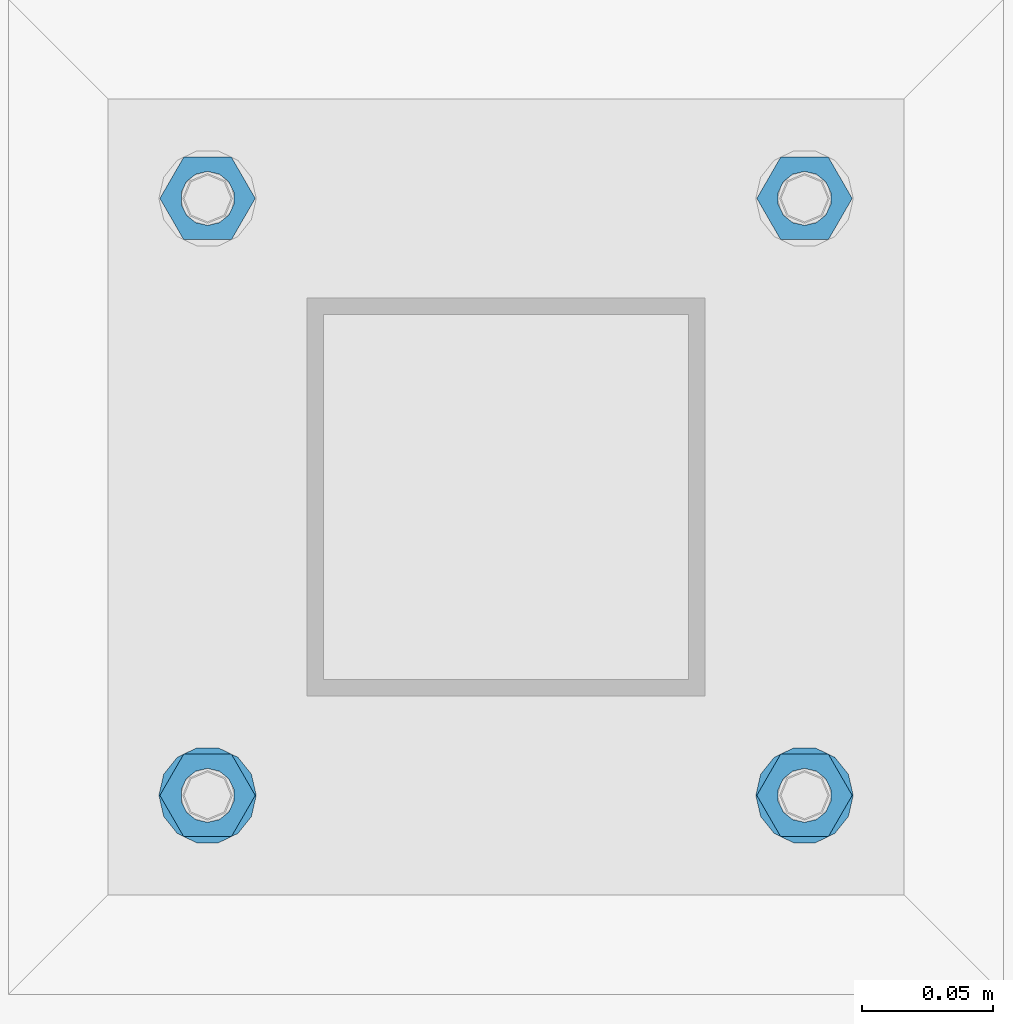
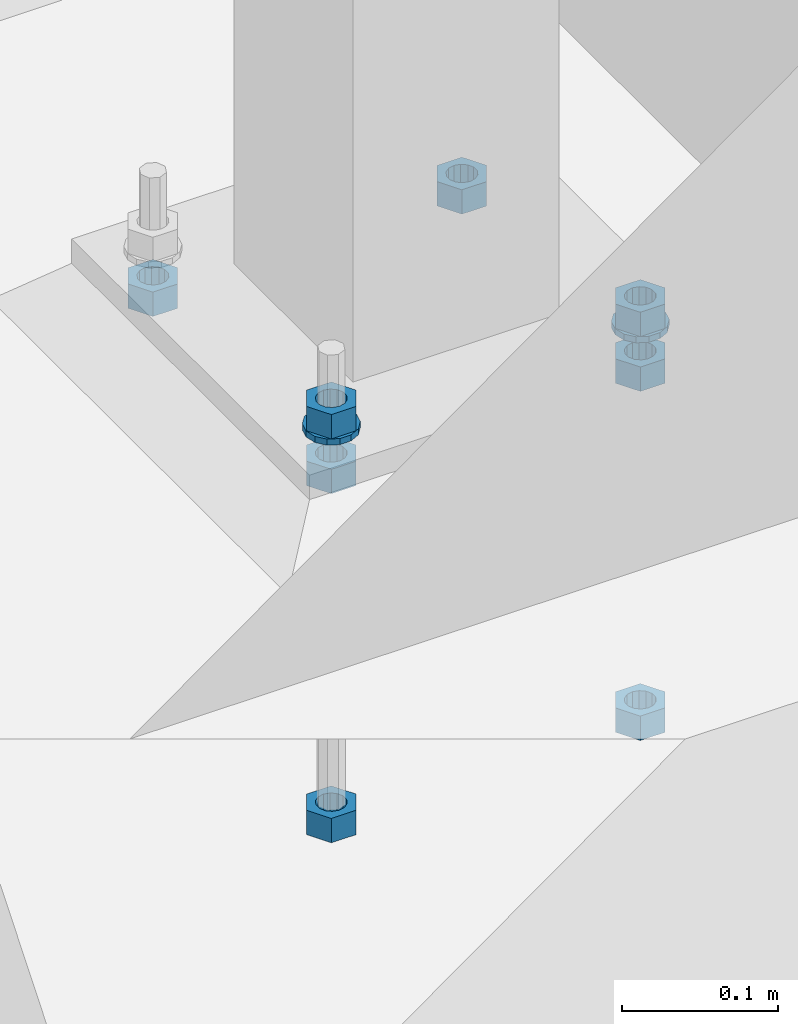
# One storey, part 962 of 1179: 10 beams, 1 element without a shape of its own.
"""IFC2X3 building model written with IfcOpenShell, lengths in millimetres."""

from ifc_helpers import new_model, si_unit, frame, origin_with_axes, place, context, subcontext, project, spatial, faceted_brep, material, type_object, element, aggregate, save


model = new_model("IFC2X3")

# Units and contexts
model_context = context("Model", 3, precision=1e-05, world=origin_with_axes())
body_context = subcontext(model_context, "Body", "Model", "MODEL_VIEW")
ifc_project = project(units=[si_unit("LENGTHUNIT", "METRE", prefix="MILLI"), si_unit("AREAUNIT", "SQUARE_METRE"), si_unit("VOLUMEUNIT", "CUBIC_METRE"), si_unit("MASSUNIT", "GRAM", prefix="KILO"), si_unit("TIMEUNIT", "SECOND"), si_unit("PLANEANGLEUNIT", "RADIAN"), si_unit("SOLIDANGLEUNIT", "STERADIAN"), si_unit("THERMODYNAMICTEMPERATUREUNIT", "DEGREE_CELSIUS"), si_unit("LUMINOUSINTENSITYUNIT", "LUMEN")], contexts=[model_context])

# Site, building, storey
site_placement = place(None, origin_with_axes())
site = spatial("IfcSite", under=ifc_project, at=site_placement, CompositionType="ELEMENT")
building_placement = place(site_placement, origin_with_axes())
building = spatial("IfcBuilding", under=site, at=building_placement, Name="Undefined", CompositionType="ELEMENT")
storey_placement = place(building_placement, origin_with_axes())
storey = spatial("IfcBuildingStorey", under=building, at=storey_placement, Name="Undefined", CompositionType="ELEMENT", Elevation=0.0)

# Assembly, beams
assembly_placement = place(storey_placement, origin_with_axes())
assembly = element("IfcElementAssembly", 1, at=assembly_placement, inside=storey, Name="TEMPLATE", AssemblyPlace="NOTDEFINED", PredefinedType="RIGID_FRAME")
ifc_material = material(Name="STEEL/A36")
beam_type_1 = type_object("IfcBeamType", Name="3/4_HEAVY_HEX_NUT", PredefinedType="NOTDEFINED")
beam_1_placement = place(assembly_placement, frame((36969.7, 2120.9, -774.7), z_axis=(0.0, -1.0, 0.0), x_axis=(0.0, 0.0, -1.0)))
beam_1 = element("IfcBeam", 2, at=beam_1_placement, type_object=beam_type_1, material=ifc_material, Name="NUT", ObjectType="3/4_HEAVY_HEX_NUT", context=body_context, shape_type="Brep", body=[
    faceted_brep([(0.0, -18.2600002288818, 0.0), (0.0, -9.13000011444092, -15.8100004196167), (19.0499999999865, -9.13000011444092, -15.8100004196167), (19.0499999999865, -18.2600002288818, 0.0), (0.0, 9.13000011444092, -15.8100004196167), (19.0499999999865, 9.13000011444092, -15.8100004196167), (0.0, 18.2600002288818, 0.0), (19.0499999999865, 18.2600002288818, 0.0), (0.0, 9.13000011444092, 15.8100004196167), (19.0499999999865, 9.13000011444092, 15.8100004196167), (0.0, -9.13000011444092, 15.8100004196167), (19.0499999999865, -9.13000011444092, 15.8100004196167), (0.0, 0.0, 10.3199996948242), (0.0, 4.47768005528246, 9.29799844179979), (19.0499999999865, 4.47768005528246, 9.29799844179979), (19.0499999999865, 0.0, 10.3199996948242), (0.0, 8.068500660474, 6.43441456490837), (19.0499999999865, 8.068500660474, 6.43441456490837), (0.0, 10.0612557561919, 2.29641597052068), (19.0499999999865, 10.0612557561919, 2.29641597052068), (0.0, 10.0612557561919, -2.29641597052068), (19.0499999999865, 10.0612557561919, -2.29641597052068), (0.0, 8.068500660474, -6.43441456490837), (19.0499999999865, 8.068500660474, -6.43441456490837), (0.0, 4.47768005528246, -9.29799844179979), (19.0499999999865, 4.47768005528246, -9.29799844179979), (0.0, 0.0, -10.3199996948242), (19.0499999999865, 0.0, -10.3199996948242), (0.0, -4.47768005528246, -9.29799844179979), (19.0499999999865, -4.47768005528246, -9.29799844179979), (0.0, -8.068500660474, -6.43441456490837), (19.0499999999865, -8.068500660474, -6.43441456490837), (0.0, -10.0612557561919, -2.29641597052068), (19.0499999999865, -10.0612557561919, -2.29641597052068), (0.0, -10.0612557561919, 2.29641597052068), (19.0499999999865, -10.0612557561919, 2.29641597052068), (0.0, -8.068500660474, 6.43441456490837), (19.0499999999865, -8.068500660474, 6.43441456490837), (0.0, -4.47768005528246, 9.29799844179979), (19.0499999999865, -4.47768005528246, 9.29799844179979)], [[[0, 1, 2, 3]], [[1, 4, 5, 2]], [[4, 6, 7, 5]], [[6, 8, 9, 7]], [[8, 10, 11, 9]], [[10, 0, 3, 11]], [[12, 13, 14, 15]], [[13, 16, 17, 14]], [[16, 18, 19, 17]], [[18, 20, 21, 19]], [[20, 22, 23, 21]], [[22, 24, 25, 23]], [[24, 26, 27, 25]], [[26, 28, 29, 27]], [[28, 30, 31, 29]], [[30, 32, 33, 31]], [[32, 34, 35, 33]], [[34, 36, 37, 35]], [[36, 38, 39, 37]], [[38, 12, 15, 39]], [[5, 7, 9, 11, 3, 2], [17, 19, 21, 23, 25, 27, 29, 31, 33, 35, 37, 39, 15, 14]], [[10, 8, 6, 4, 1, 0], [38, 36, 34, 32, 30, 28, 26, 24, 22, 20, 18, 16, 13, 12]]]),
])
beam_2_placement = place(assembly_placement, frame((37198.3, 2120.9, -774.7), z_axis=(0.0, 1.0, 0.0), x_axis=(0.0, 0.0, -1.0)))
beam_2 = element("IfcBeam", 3, at=beam_2_placement, type_object=beam_type_1, material=ifc_material, Name="NUT", ObjectType="3/4_HEAVY_HEX_NUT", context=body_context, shape_type="Brep", body=[
    faceted_brep([(0.0, -18.2600002288818, 0.0), (0.0, -9.13000011444092, -15.8100004196167), (19.0499999999865, -9.13000011444092, -15.8100004196167), (19.0499999999865, -18.2600002288818, 0.0), (0.0, 9.13000011444092, -15.8100004196167), (19.0499999999865, 9.13000011444092, -15.8100004196167), (0.0, 18.2600002288818, 0.0), (19.0499999999865, 18.2600002288818, 0.0), (0.0, 9.13000011444092, 15.8100004196167), (19.0499999999865, 9.13000011444092, 15.8100004196167), (0.0, -9.13000011444092, 15.8100004196167), (19.0499999999865, -9.13000011444092, 15.8100004196167), (0.0, 0.0, 10.3199996948242), (0.0, 4.47768005528246, 9.29799844179979), (19.0499999999865, 4.47768005528246, 9.29799844179979), (19.0499999999865, 0.0, 10.3199996948242), (0.0, 8.068500660474, 6.43441456490837), (19.0499999999865, 8.068500660474, 6.43441456490837), (0.0, 10.0612557561919, 2.29641597052068), (19.0499999999865, 10.0612557561919, 2.29641597052068), (0.0, 10.0612557561919, -2.29641597052068), (19.0499999999865, 10.0612557561919, -2.29641597052068), (0.0, 8.068500660474, -6.43441456490837), (19.0499999999865, 8.068500660474, -6.43441456490837), (0.0, 4.47768005528246, -9.29799844179979), (19.0499999999865, 4.47768005528246, -9.29799844179979), (0.0, 0.0, -10.3199996948242), (19.0499999999865, 0.0, -10.3199996948242), (0.0, -4.47768005528246, -9.29799844179979), (19.0499999999865, -4.47768005528246, -9.29799844179979), (0.0, -8.068500660474, -6.43441456490837), (19.0499999999865, -8.068500660474, -6.43441456490837), (0.0, -10.0612557561919, -2.29641597052068), (19.0499999999865, -10.0612557561919, -2.29641597052068), (0.0, -10.0612557561919, 2.29641597052068), (19.0499999999865, -10.0612557561919, 2.29641597052068), (0.0, -8.068500660474, 6.43441456490837), (19.0499999999865, -8.068500660474, 6.43441456490837), (0.0, -4.47768005528246, 9.29799844179979), (19.0499999999865, -4.47768005528246, 9.29799844179979)], [[[0, 1, 2, 3]], [[1, 4, 5, 2]], [[4, 6, 7, 5]], [[6, 8, 9, 7]], [[8, 10, 11, 9]], [[10, 0, 3, 11]], [[12, 13, 14, 15]], [[13, 16, 17, 14]], [[16, 18, 19, 17]], [[18, 20, 21, 19]], [[20, 22, 23, 21]], [[22, 24, 25, 23]], [[24, 26, 27, 25]], [[26, 28, 29, 27]], [[28, 30, 31, 29]], [[30, 32, 33, 31]], [[32, 34, 35, 33]], [[34, 36, 37, 35]], [[36, 38, 39, 37]], [[38, 12, 15, 39]], [[5, 7, 9, 11, 3, 2], [17, 19, 21, 23, 25, 27, 29, 31, 33, 35, 37, 39, 15, 14]], [[10, 8, 6, 4, 1, 0], [38, 36, 34, 32, 30, 28, 26, 24, 22, 20, 18, 16, 13, 12]]]),
])
beam_3_placement = place(assembly_placement, frame((36969.7, 2349.5, -774.7), z_axis=(0.0, -1.0, 0.0), x_axis=(0.0, 0.0, -1.0)))
beam_3 = element("IfcBeam", 4, at=beam_3_placement, type_object=beam_type_1, material=ifc_material, Name="NUT", ObjectType="3/4_HEAVY_HEX_NUT", context=body_context, shape_type="Brep", body=[
    faceted_brep([(0.0, -18.2600002288818, 0.0), (0.0, -9.13000011444092, -15.8100004196167), (19.0499999999865, -9.13000011444092, -15.8100004196167), (19.0499999999865, -18.2600002288818, 0.0), (0.0, 9.13000011444092, -15.8100004196167), (19.0499999999865, 9.13000011444092, -15.8100004196167), (0.0, 18.2600002288818, 0.0), (19.0499999999865, 18.2600002288818, 0.0), (0.0, 9.13000011444092, 15.8100004196167), (19.0499999999865, 9.13000011444092, 15.8100004196167), (0.0, -9.13000011444092, 15.8100004196167), (19.0499999999865, -9.13000011444092, 15.8100004196167), (0.0, 0.0, 10.3199996948242), (0.0, 4.47768005528246, 9.29799844179979), (19.0499999999865, 4.47768005528246, 9.29799844179979), (19.0499999999865, 0.0, 10.3199996948242), (0.0, 8.068500660474, 6.43441456490837), (19.0499999999865, 8.068500660474, 6.43441456490837), (0.0, 10.0612557561919, 2.29641597052068), (19.0499999999865, 10.0612557561919, 2.29641597052068), (0.0, 10.0612557561919, -2.29641597052068), (19.0499999999865, 10.0612557561919, -2.29641597052068), (0.0, 8.068500660474, -6.43441456490837), (19.0499999999865, 8.068500660474, -6.43441456490837), (0.0, 4.47768005528246, -9.29799844179979), (19.0499999999865, 4.47768005528246, -9.29799844179979), (0.0, 0.0, -10.3199996948242), (19.0499999999865, 0.0, -10.3199996948242), (0.0, -4.47768005528246, -9.29799844179979), (19.0499999999865, -4.47768005528246, -9.29799844179979), (0.0, -8.068500660474, -6.43441456490837), (19.0499999999865, -8.068500660474, -6.43441456490837), (0.0, -10.0612557561919, -2.29641597052068), (19.0499999999865, -10.0612557561919, -2.29641597052068), (0.0, -10.0612557561919, 2.29641597052068), (19.0499999999865, -10.0612557561919, 2.29641597052068), (0.0, -8.068500660474, 6.43441456490837), (19.0499999999865, -8.068500660474, 6.43441456490837), (0.0, -4.47768005528246, 9.29799844179979), (19.0499999999865, -4.47768005528246, 9.29799844179979)], [[[0, 1, 2, 3]], [[1, 4, 5, 2]], [[4, 6, 7, 5]], [[6, 8, 9, 7]], [[8, 10, 11, 9]], [[10, 0, 3, 11]], [[12, 13, 14, 15]], [[13, 16, 17, 14]], [[16, 18, 19, 17]], [[18, 20, 21, 19]], [[20, 22, 23, 21]], [[22, 24, 25, 23]], [[24, 26, 27, 25]], [[26, 28, 29, 27]], [[28, 30, 31, 29]], [[30, 32, 33, 31]], [[32, 34, 35, 33]], [[34, 36, 37, 35]], [[36, 38, 39, 37]], [[38, 12, 15, 39]], [[5, 7, 9, 11, 3, 2], [17, 19, 21, 23, 25, 27, 29, 31, 33, 35, 37, 39, 15, 14]], [[10, 8, 6, 4, 1, 0], [38, 36, 34, 32, 30, 28, 26, 24, 22, 20, 18, 16, 13, 12]]]),
])
beam_4_placement = place(assembly_placement, frame((37198.3, 2349.5, -774.7), z_axis=(0.0, 1.0, 0.0), x_axis=(0.0, 0.0, -1.0)))
beam_4 = element("IfcBeam", 5, at=beam_4_placement, type_object=beam_type_1, material=ifc_material, Name="NUT", ObjectType="3/4_HEAVY_HEX_NUT", context=body_context, shape_type="Brep", body=[
    faceted_brep([(0.0, -18.2600002288818, 0.0), (0.0, -9.13000011444092, -15.8100004196167), (19.0499999999865, -9.13000011444092, -15.8100004196167), (19.0499999999865, -18.2600002288818, 0.0), (0.0, 9.13000011444092, -15.8100004196167), (19.0499999999865, 9.13000011444092, -15.8100004196167), (0.0, 18.2600002288818, 0.0), (19.0499999999865, 18.2600002288818, 0.0), (0.0, 9.13000011444092, 15.8100004196167), (19.0499999999865, 9.13000011444092, 15.8100004196167), (0.0, -9.13000011444092, 15.8100004196167), (19.0499999999865, -9.13000011444092, 15.8100004196167), (0.0, 0.0, 10.3199996948242), (0.0, 4.47768005528246, 9.29799844179979), (19.0499999999865, 4.47768005528246, 9.29799844179979), (19.0499999999865, 0.0, 10.3199996948242), (0.0, 8.068500660474, 6.43441456490837), (19.0499999999865, 8.068500660474, 6.43441456490837), (0.0, 10.0612557561919, 2.29641597052068), (19.0499999999865, 10.0612557561919, 2.29641597052068), (0.0, 10.0612557561919, -2.29641597052068), (19.0499999999865, 10.0612557561919, -2.29641597052068), (0.0, 8.068500660474, -6.43441456490837), (19.0499999999865, 8.068500660474, -6.43441456490837), (0.0, 4.47768005528246, -9.29799844179979), (19.0499999999865, 4.47768005528246, -9.29799844179979), (0.0, 0.0, -10.3199996948242), (19.0499999999865, 0.0, -10.3199996948242), (0.0, -4.47768005528246, -9.29799844179979), (19.0499999999865, -4.47768005528246, -9.29799844179979), (0.0, -8.068500660474, -6.43441456490837), (19.0499999999865, -8.068500660474, -6.43441456490837), (0.0, -10.0612557561919, -2.29641597052068), (19.0499999999865, -10.0612557561919, -2.29641597052068), (0.0, -10.0612557561919, 2.29641597052068), (19.0499999999865, -10.0612557561919, 2.29641597052068), (0.0, -8.068500660474, 6.43441456490837), (19.0499999999865, -8.068500660474, 6.43441456490837), (0.0, -4.47768005528246, 9.29799844179979), (19.0499999999865, -4.47768005528246, 9.29799844179979)], [[[0, 1, 2, 3]], [[1, 4, 5, 2]], [[4, 6, 7, 5]], [[6, 8, 9, 7]], [[8, 10, 11, 9]], [[10, 0, 3, 11]], [[12, 13, 14, 15]], [[13, 16, 17, 14]], [[16, 18, 19, 17]], [[18, 20, 21, 19]], [[20, 22, 23, 21]], [[22, 24, 25, 23]], [[24, 26, 27, 25]], [[26, 28, 29, 27]], [[28, 30, 31, 29]], [[30, 32, 33, 31]], [[32, 34, 35, 33]], [[34, 36, 37, 35]], [[36, 38, 39, 37]], [[38, 12, 15, 39]], [[5, 7, 9, 11, 3, 2], [17, 19, 21, 23, 25, 27, 29, 31, 33, 35, 37, 39, 15, 14]], [[10, 8, 6, 4, 1, 0], [38, 36, 34, 32, 30, 28, 26, 24, 22, 20, 18, 16, 13, 12]]]),
])
beam_5_placement = place(assembly_placement, frame((36969.7, 2120.9, -731.8375), z_axis=(0.0, -1.0, 0.0), x_axis=(0.0, 0.0, -1.0)))
beam_5 = element("IfcBeam", 6, at=beam_5_placement, type_object=beam_type_1, material=ifc_material, Name="NUT", ObjectType="3/4_HEAVY_HEX_NUT", context=body_context, shape_type="Brep", body=[
    faceted_brep([(0.0, -18.2600002288818, 0.0), (0.0, -9.13000011444092, -15.8100004196167), (19.0499999999865, -9.13000011444092, -15.8100004196167), (19.0499999999865, -18.2600002288818, 0.0), (0.0, 9.13000011444092, -15.8100004196167), (19.0499999999865, 9.13000011444092, -15.8100004196167), (0.0, 18.2600002288818, 0.0), (19.0499999999865, 18.2600002288818, 0.0), (0.0, 9.13000011444092, 15.8100004196167), (19.0499999999865, 9.13000011444092, 15.8100004196167), (0.0, -9.13000011444092, 15.8100004196167), (19.0499999999865, -9.13000011444092, 15.8100004196167), (0.0, 0.0, 10.3199996948242), (0.0, 4.47768005528246, 9.29799844179979), (19.0499999999865, 4.47768005528246, 9.29799844179979), (19.0499999999865, 0.0, 10.3199996948242), (0.0, 8.068500660474, 6.43441456490837), (19.0499999999865, 8.068500660474, 6.43441456490837), (0.0, 10.0612557561919, 2.29641597052068), (19.0499999999865, 10.0612557561919, 2.29641597052068), (0.0, 10.0612557561919, -2.29641597052068), (19.0499999999865, 10.0612557561919, -2.29641597052068), (0.0, 8.068500660474, -6.43441456490837), (19.0499999999865, 8.068500660474, -6.43441456490837), (0.0, 4.47768005528246, -9.29799844179979), (19.0499999999865, 4.47768005528246, -9.29799844179979), (0.0, 0.0, -10.3199996948242), (19.0499999999865, 0.0, -10.3199996948242), (0.0, -4.47768005528246, -9.29799844179979), (19.0499999999865, -4.47768005528246, -9.29799844179979), (0.0, -8.068500660474, -6.43441456490837), (19.0499999999865, -8.068500660474, -6.43441456490837), (0.0, -10.0612557561919, -2.29641597052068), (19.0499999999865, -10.0612557561919, -2.29641597052068), (0.0, -10.0612557561919, 2.29641597052068), (19.0499999999865, -10.0612557561919, 2.29641597052068), (0.0, -8.068500660474, 6.43441456490837), (19.0499999999865, -8.068500660474, 6.43441456490837), (0.0, -4.47768005528246, 9.29799844179979), (19.0499999999865, -4.47768005528246, 9.29799844179979)], [[[0, 1, 2, 3]], [[1, 4, 5, 2]], [[4, 6, 7, 5]], [[6, 8, 9, 7]], [[8, 10, 11, 9]], [[10, 0, 3, 11]], [[12, 13, 14, 15]], [[13, 16, 17, 14]], [[16, 18, 19, 17]], [[18, 20, 21, 19]], [[20, 22, 23, 21]], [[22, 24, 25, 23]], [[24, 26, 27, 25]], [[26, 28, 29, 27]], [[28, 30, 31, 29]], [[30, 32, 33, 31]], [[32, 34, 35, 33]], [[34, 36, 37, 35]], [[36, 38, 39, 37]], [[38, 12, 15, 39]], [[5, 7, 9, 11, 3, 2], [17, 19, 21, 23, 25, 27, 29, 31, 33, 35, 37, 39, 15, 14]], [[10, 8, 6, 4, 1, 0], [38, 36, 34, 32, 30, 28, 26, 24, 22, 20, 18, 16, 13, 12]]]),
])
beam_6_placement = place(assembly_placement, frame((36969.7, 2120.9, -1047.75), z_axis=(0.0, -1.0, 0.0), x_axis=(0.0, 0.0, -1.0)))
beam_6 = element("IfcBeam", 7, at=beam_6_placement, type_object=beam_type_1, material=ifc_material, Name="NUT", ObjectType="3/4_HEAVY_HEX_NUT", context=body_context, shape_type="Brep", body=[
    faceted_brep([(0.0, -18.2600002288818, 0.0), (0.0, -9.13000011444092, -15.8100004196167), (19.0499999999865, -9.13000011444092, -15.8100004196167), (19.0499999999865, -18.2600002288818, 0.0), (0.0, 9.13000011444092, -15.8100004196167), (19.0499999999865, 9.13000011444092, -15.8100004196167), (0.0, 18.2600002288818, 0.0), (19.0499999999865, 18.2600002288818, 0.0), (0.0, 9.13000011444092, 15.8100004196167), (19.0499999999865, 9.13000011444092, 15.8100004196167), (0.0, -9.13000011444092, 15.8100004196167), (19.0499999999865, -9.13000011444092, 15.8100004196167), (0.0, 0.0, 10.3199996948242), (0.0, 4.47768005528246, 9.29799844179979), (19.0499999999865, 4.47768005528246, 9.29799844179979), (19.0499999999865, 0.0, 10.3199996948242), (0.0, 8.068500660474, 6.43441456490837), (19.0499999999865, 8.068500660474, 6.43441456490837), (0.0, 10.0612557561919, 2.29641597052068), (19.0499999999865, 10.0612557561919, 2.29641597052068), (0.0, 10.0612557561919, -2.29641597052068), (19.0499999999865, 10.0612557561919, -2.29641597052068), (0.0, 8.068500660474, -6.43441456490837), (19.0499999999865, 8.068500660474, -6.43441456490837), (0.0, 4.47768005528246, -9.29799844179979), (19.0499999999865, 4.47768005528246, -9.29799844179979), (0.0, 0.0, -10.3199996948242), (19.0499999999865, 0.0, -10.3199996948242), (0.0, -4.47768005528246, -9.29799844179979), (19.0499999999865, -4.47768005528246, -9.29799844179979), (0.0, -8.068500660474, -6.43441456490837), (19.0499999999865, -8.068500660474, -6.43441456490837), (0.0, -10.0612557561919, -2.29641597052068), (19.0499999999865, -10.0612557561919, -2.29641597052068), (0.0, -10.0612557561919, 2.29641597052068), (19.0499999999865, -10.0612557561919, 2.29641597052068), (0.0, -8.068500660474, 6.43441456490837), (19.0499999999865, -8.068500660474, 6.43441456490837), (0.0, -4.47768005528246, 9.29799844179979), (19.0499999999865, -4.47768005528246, 9.29799844179979)], [[[0, 1, 2, 3]], [[1, 4, 5, 2]], [[4, 6, 7, 5]], [[6, 8, 9, 7]], [[8, 10, 11, 9]], [[10, 0, 3, 11]], [[12, 13, 14, 15]], [[13, 16, 17, 14]], [[16, 18, 19, 17]], [[18, 20, 21, 19]], [[20, 22, 23, 21]], [[22, 24, 25, 23]], [[24, 26, 27, 25]], [[26, 28, 29, 27]], [[28, 30, 31, 29]], [[30, 32, 33, 31]], [[32, 34, 35, 33]], [[34, 36, 37, 35]], [[36, 38, 39, 37]], [[38, 12, 15, 39]], [[5, 7, 9, 11, 3, 2], [17, 19, 21, 23, 25, 27, 29, 31, 33, 35, 37, 39, 15, 14]], [[10, 8, 6, 4, 1, 0], [38, 36, 34, 32, 30, 28, 26, 24, 22, 20, 18, 16, 13, 12]]]),
])
beam_7_placement = place(assembly_placement, frame((37198.3, 2120.9, -731.8375), z_axis=(0.0, 1.0, 0.0), x_axis=(0.0, 0.0, -1.0)))
beam_7 = element("IfcBeam", 8, at=beam_7_placement, type_object=beam_type_1, material=ifc_material, Name="NUT", ObjectType="3/4_HEAVY_HEX_NUT", context=body_context, shape_type="Brep", body=[
    faceted_brep([(0.0, -18.2600002288818, 0.0), (0.0, -9.13000011444092, -15.8100004196167), (19.0499999999865, -9.13000011444092, -15.8100004196167), (19.0499999999865, -18.2600002288818, 0.0), (0.0, 9.13000011444092, -15.8100004196167), (19.0499999999865, 9.13000011444092, -15.8100004196167), (0.0, 18.2600002288818, 0.0), (19.0499999999865, 18.2600002288818, 0.0), (0.0, 9.13000011444092, 15.8100004196167), (19.0499999999865, 9.13000011444092, 15.8100004196167), (0.0, -9.13000011444092, 15.8100004196167), (19.0499999999865, -9.13000011444092, 15.8100004196167), (0.0, 0.0, 10.3199996948242), (0.0, 4.47768005528246, 9.29799844179979), (19.0499999999865, 4.47768005528246, 9.29799844179979), (19.0499999999865, 0.0, 10.3199996948242), (0.0, 8.068500660474, 6.43441456490837), (19.0499999999865, 8.068500660474, 6.43441456490837), (0.0, 10.0612557561919, 2.29641597052068), (19.0499999999865, 10.0612557561919, 2.29641597052068), (0.0, 10.0612557561919, -2.29641597052068), (19.0499999999865, 10.0612557561919, -2.29641597052068), (0.0, 8.068500660474, -6.43441456490837), (19.0499999999865, 8.068500660474, -6.43441456490837), (0.0, 4.47768005528246, -9.29799844179979), (19.0499999999865, 4.47768005528246, -9.29799844179979), (0.0, 0.0, -10.3199996948242), (19.0499999999865, 0.0, -10.3199996948242), (0.0, -4.47768005528246, -9.29799844179979), (19.0499999999865, -4.47768005528246, -9.29799844179979), (0.0, -8.068500660474, -6.43441456490837), (19.0499999999865, -8.068500660474, -6.43441456490837), (0.0, -10.0612557561919, -2.29641597052068), (19.0499999999865, -10.0612557561919, -2.29641597052068), (0.0, -10.0612557561919, 2.29641597052068), (19.0499999999865, -10.0612557561919, 2.29641597052068), (0.0, -8.068500660474, 6.43441456490837), (19.0499999999865, -8.068500660474, 6.43441456490837), (0.0, -4.47768005528246, 9.29799844179979), (19.0499999999865, -4.47768005528246, 9.29799844179979)], [[[0, 1, 2, 3]], [[1, 4, 5, 2]], [[4, 6, 7, 5]], [[6, 8, 9, 7]], [[8, 10, 11, 9]], [[10, 0, 3, 11]], [[12, 13, 14, 15]], [[13, 16, 17, 14]], [[16, 18, 19, 17]], [[18, 20, 21, 19]], [[20, 22, 23, 21]], [[22, 24, 25, 23]], [[24, 26, 27, 25]], [[26, 28, 29, 27]], [[28, 30, 31, 29]], [[30, 32, 33, 31]], [[32, 34, 35, 33]], [[34, 36, 37, 35]], [[36, 38, 39, 37]], [[38, 12, 15, 39]], [[5, 7, 9, 11, 3, 2], [17, 19, 21, 23, 25, 27, 29, 31, 33, 35, 37, 39, 15, 14]], [[10, 8, 6, 4, 1, 0], [38, 36, 34, 32, 30, 28, 26, 24, 22, 20, 18, 16, 13, 12]]]),
])
beam_8_placement = place(assembly_placement, frame((37198.3, 2120.9, -1047.75), z_axis=(0.0, 1.0, 0.0), x_axis=(0.0, 0.0, -1.0)))
beam_8 = element("IfcBeam", 9, at=beam_8_placement, type_object=beam_type_1, material=ifc_material, Name="NUT", ObjectType="3/4_HEAVY_HEX_NUT", context=body_context, shape_type="Brep", body=[
    faceted_brep([(0.0, -18.2600002288818, 0.0), (0.0, -9.13000011444092, -15.8100004196167), (19.0499999999865, -9.13000011444092, -15.8100004196167), (19.0499999999865, -18.2600002288818, 0.0), (0.0, 9.13000011444092, -15.8100004196167), (19.0499999999865, 9.13000011444092, -15.8100004196167), (0.0, 18.2600002288818, 0.0), (19.0499999999865, 18.2600002288818, 0.0), (0.0, 9.13000011444092, 15.8100004196167), (19.0499999999865, 9.13000011444092, 15.8100004196167), (0.0, -9.13000011444092, 15.8100004196167), (19.0499999999865, -9.13000011444092, 15.8100004196167), (0.0, 0.0, 10.3199996948242), (0.0, 4.47768005528246, 9.29799844179979), (19.0499999999865, 4.47768005528246, 9.29799844179979), (19.0499999999865, 0.0, 10.3199996948242), (0.0, 8.068500660474, 6.43441456490837), (19.0499999999865, 8.068500660474, 6.43441456490837), (0.0, 10.0612557561919, 2.29641597052068), (19.0499999999865, 10.0612557561919, 2.29641597052068), (0.0, 10.0612557561919, -2.29641597052068), (19.0499999999865, 10.0612557561919, -2.29641597052068), (0.0, 8.068500660474, -6.43441456490837), (19.0499999999865, 8.068500660474, -6.43441456490837), (0.0, 4.47768005528246, -9.29799844179979), (19.0499999999865, 4.47768005528246, -9.29799844179979), (0.0, 0.0, -10.3199996948242), (19.0499999999865, 0.0, -10.3199996948242), (0.0, -4.47768005528246, -9.29799844179979), (19.0499999999865, -4.47768005528246, -9.29799844179979), (0.0, -8.068500660474, -6.43441456490837), (19.0499999999865, -8.068500660474, -6.43441456490837), (0.0, -10.0612557561919, -2.29641597052068), (19.0499999999865, -10.0612557561919, -2.29641597052068), (0.0, -10.0612557561919, 2.29641597052068), (19.0499999999865, -10.0612557561919, 2.29641597052068), (0.0, -8.068500660474, 6.43441456490837), (19.0499999999865, -8.068500660474, 6.43441456490837), (0.0, -4.47768005528246, 9.29799844179979), (19.0499999999865, -4.47768005528246, 9.29799844179979)], [[[0, 1, 2, 3]], [[1, 4, 5, 2]], [[4, 6, 7, 5]], [[6, 8, 9, 7]], [[8, 10, 11, 9]], [[10, 0, 3, 11]], [[12, 13, 14, 15]], [[13, 16, 17, 14]], [[16, 18, 19, 17]], [[18, 20, 21, 19]], [[20, 22, 23, 21]], [[22, 24, 25, 23]], [[24, 26, 27, 25]], [[26, 28, 29, 27]], [[28, 30, 31, 29]], [[30, 32, 33, 31]], [[32, 34, 35, 33]], [[34, 36, 37, 35]], [[36, 38, 39, 37]], [[38, 12, 15, 39]], [[5, 7, 9, 11, 3, 2], [17, 19, 21, 23, 25, 27, 29, 31, 33, 35, 37, 39, 15, 14]], [[10, 8, 6, 4, 1, 0], [38, 36, 34, 32, 30, 28, 26, 24, 22, 20, 18, 16, 13, 12]]]),
])
beam_type_2 = type_object("IfcBeamType", Name="3/4_WASHER", PredefinedType="NOTDEFINED")
beam_9_placement = place(assembly_placement, frame((36969.7, 2120.9, -750.8875), z_axis=(0.0, -1.0, 0.0), x_axis=(0.0, 0.0, -1.0)))
beam_9 = element("IfcBeam", 10, at=beam_9_placement, type_object=beam_type_2, material=ifc_material, Name="WASHER", ObjectType="3/4_WASHER", context=body_context, shape_type="Brep", body=[
    faceted_brep([(0.0, -18.6499996185303, 0.0), (0.0, -16.8030690426895, -8.09193156902893), (4.76249999999993, -16.8030690426895, -8.09193156902893), (4.76249999999993, -18.6499996185303, 0.0), (0.0, -11.6280845668225, -14.5811568497838), (4.76249999999993, -11.6280845668225, -14.5811568497838), (0.0, -4.15001533339819, -18.1824051902859), (4.76249999999993, -4.15001533339819, -18.1824051902859), (0.0, 4.15001533339819, -18.1824051902859), (4.76249999999993, 4.15001533339819, -18.1824051902859), (0.0, 11.6280845668225, -14.5811568497838), (4.76249999999993, 11.6280845668225, -14.5811568497838), (0.0, 16.8030690426895, -8.09193156902893), (4.76249999999993, 16.8030690426895, -8.09193156902893), (0.0, 18.6499996185303, 0.0), (4.76249999999993, 18.6499996185303, 0.0), (0.0, 16.8030690426895, 8.09193156902893), (4.76249999999993, 16.8030690426895, 8.09193156902893), (0.0, 11.6280845668225, 14.5811568497838), (4.76249999999993, 11.6280845668225, 14.5811568497838), (0.0, 4.15001533339819, 18.1824051902859), (4.76249999999993, 4.15001533339819, 18.1824051902859), (0.0, -4.15001533339819, 18.1824051902859), (4.76249999999993, -4.15001533339819, 18.1824051902859), (0.0, -11.6280845668225, 14.5811568497838), (4.76249999999993, -11.6280845668225, 14.5811568497838), (0.0, -16.8030690426895, 8.09193156902893), (4.76249999999993, -16.8030690426895, 8.09193156902893), (0.0, 0.0, 10.3199996948242), (0.0, 4.47768005528246, 9.29799844179979), (4.76249999999993, 4.47768005527905, 9.29799844179888), (4.76249999999993, 0.0, 10.3199996948242), (0.0, 8.068500660474, 6.43441456490837), (4.76249999999993, 8.06850066047627, 6.43441456490837), (0.0, 10.0612557561919, 2.29641597052068), (4.76249999999993, 10.0612557561908, 2.29641597052114), (0.0, 10.0612557561919, -2.29641597052068), (4.76249999999993, 10.0612557561908, -2.29641597052114), (0.0, 8.068500660474, -6.43441456490837), (4.76249999999993, 8.06850066047627, -6.43441456490791), (0.0, 4.47768005528246, -9.29799844179979), (4.76249999999993, 4.47768005527905, -9.29799844179888), (0.0, 0.0, -10.3199996948242), (4.76249999999993, 0.0, -10.3199996948242), (0.0, -4.47768005528246, -9.29799844179979), (4.76249999999993, -4.47768005527905, -9.29799844179888), (0.0, -8.068500660474, -6.43441456490837), (4.76249999999993, -8.06850066047627, -6.43441456490837), (0.0, -10.0612557561919, -2.29641597052068), (4.76249999999993, -10.0612557561908, -2.29641597052114), (0.0, -10.0612557561919, 2.29641597052068), (4.76249999999993, -10.0612557561908, 2.29641597052114), (0.0, -8.068500660474, 6.43441456490837), (4.76249999999993, -8.06850066047627, 6.43441456490791), (0.0, -4.47768005528246, 9.29799844179979), (4.76249999999993, -4.47768005527905, 9.29799844179888)], [[[0, 1, 2, 3]], [[1, 4, 5, 2]], [[4, 6, 7, 5]], [[6, 8, 9, 7]], [[8, 10, 11, 9]], [[10, 12, 13, 11]], [[12, 14, 15, 13]], [[14, 16, 17, 15]], [[16, 18, 19, 17]], [[18, 20, 21, 19]], [[20, 22, 23, 21]], [[22, 24, 25, 23]], [[24, 26, 27, 25]], [[26, 0, 3, 27]], [[28, 29, 30, 31]], [[29, 32, 33, 30]], [[32, 34, 35, 33]], [[34, 36, 37, 35]], [[36, 38, 39, 37]], [[38, 40, 41, 39]], [[40, 42, 43, 41]], [[42, 44, 45, 43]], [[44, 46, 47, 45]], [[46, 48, 49, 47]], [[48, 50, 51, 49]], [[50, 52, 53, 51]], [[52, 54, 55, 53]], [[54, 28, 31, 55]], [[5, 7, 9, 11, 13, 15, 17, 19, 21, 23, 25, 27, 3, 2], [33, 35, 37, 39, 41, 43, 45, 47, 49, 51, 53, 55, 31, 30]], [[26, 24, 22, 20, 18, 16, 14, 12, 10, 8, 6, 4, 1, 0], [54, 52, 50, 48, 46, 44, 42, 40, 38, 36, 34, 32, 29, 28]]]),
])
beam_10_placement = place(assembly_placement, frame((37198.3, 2120.9, -750.8875), z_axis=(0.0, 1.0, 0.0), x_axis=(0.0, 0.0, -1.0)))
beam_10 = element("IfcBeam", 11, at=beam_10_placement, type_object=beam_type_2, material=ifc_material, Name="WASHER", ObjectType="3/4_WASHER", context=body_context, shape_type="Brep", body=[
    faceted_brep([(0.0, -18.6499996185303, 0.0), (0.0, -16.8030690426895, -8.09193156902893), (4.76249999999993, -16.8030690426895, -8.09193156902893), (4.76249999999993, -18.6499996185303, 0.0), (0.0, -11.6280845668225, -14.5811568497838), (4.76249999999993, -11.6280845668225, -14.5811568497838), (0.0, -4.15001533339819, -18.1824051902859), (4.76249999999993, -4.15001533339819, -18.1824051902859), (0.0, 4.15001533339819, -18.1824051902859), (4.76249999999993, 4.15001533339819, -18.1824051902859), (0.0, 11.6280845668225, -14.5811568497838), (4.76249999999993, 11.6280845668225, -14.5811568497838), (0.0, 16.8030690426895, -8.09193156902893), (4.76249999999993, 16.8030690426895, -8.09193156902893), (0.0, 18.6499996185303, 0.0), (4.76249999999993, 18.6499996185303, 0.0), (0.0, 16.8030690426895, 8.09193156902893), (4.76249999999993, 16.8030690426895, 8.09193156902893), (0.0, 11.6280845668225, 14.5811568497838), (4.76249999999993, 11.6280845668225, 14.5811568497838), (0.0, 4.15001533339819, 18.1824051902859), (4.76249999999993, 4.15001533339819, 18.1824051902859), (0.0, -4.15001533339819, 18.1824051902859), (4.76249999999993, -4.15001533339819, 18.1824051902859), (0.0, -11.6280845668225, 14.5811568497838), (4.76249999999993, -11.6280845668225, 14.5811568497838), (0.0, -16.8030690426895, 8.09193156902893), (4.76249999999993, -16.8030690426895, 8.09193156902893), (0.0, 0.0, 10.3199996948242), (0.0, 4.47768005528246, 9.29799844179979), (4.76249999999993, 4.47768005527905, 9.29799844179888), (4.76249999999993, 0.0, 10.3199996948242), (0.0, 8.068500660474, 6.43441456490837), (4.76249999999993, 8.06850066047627, 6.43441456490837), (0.0, 10.0612557561919, 2.29641597052068), (4.76249999999993, 10.0612557561908, 2.29641597052114), (0.0, 10.0612557561919, -2.29641597052068), (4.76249999999993, 10.0612557561908, -2.29641597052114), (0.0, 8.068500660474, -6.43441456490837), (4.76249999999993, 8.06850066047627, -6.43441456490791), (0.0, 4.47768005528246, -9.29799844179979), (4.76249999999993, 4.47768005527905, -9.29799844179888), (0.0, 0.0, -10.3199996948242), (4.76249999999993, 0.0, -10.3199996948242), (0.0, -4.47768005528246, -9.29799844179979), (4.76249999999993, -4.47768005527905, -9.29799844179888), (0.0, -8.068500660474, -6.43441456490837), (4.76249999999993, -8.06850066047627, -6.43441456490837), (0.0, -10.0612557561919, -2.29641597052068), (4.76249999999993, -10.0612557561908, -2.29641597052114), (0.0, -10.0612557561919, 2.29641597052068), (4.76249999999993, -10.0612557561908, 2.29641597052114), (0.0, -8.068500660474, 6.43441456490837), (4.76249999999993, -8.06850066047627, 6.43441456490791), (0.0, -4.47768005528246, 9.29799844179979), (4.76249999999993, -4.47768005527905, 9.29799844179888)], [[[0, 1, 2, 3]], [[1, 4, 5, 2]], [[4, 6, 7, 5]], [[6, 8, 9, 7]], [[8, 10, 11, 9]], [[10, 12, 13, 11]], [[12, 14, 15, 13]], [[14, 16, 17, 15]], [[16, 18, 19, 17]], [[18, 20, 21, 19]], [[20, 22, 23, 21]], [[22, 24, 25, 23]], [[24, 26, 27, 25]], [[26, 0, 3, 27]], [[28, 29, 30, 31]], [[29, 32, 33, 30]], [[32, 34, 35, 33]], [[34, 36, 37, 35]], [[36, 38, 39, 37]], [[38, 40, 41, 39]], [[40, 42, 43, 41]], [[42, 44, 45, 43]], [[44, 46, 47, 45]], [[46, 48, 49, 47]], [[48, 50, 51, 49]], [[50, 52, 53, 51]], [[52, 54, 55, 53]], [[54, 28, 31, 55]], [[5, 7, 9, 11, 13, 15, 17, 19, 21, 23, 25, 27, 3, 2], [33, 35, 37, 39, 41, 43, 45, 47, 49, 51, 53, 55, 31, 30]], [[26, 24, 22, 20, 18, 16, 14, 12, 10, 8, 6, 4, 1, 0], [54, 52, 50, 48, 46, 44, 42, 40, 38, 36, 34, 32, 29, 28]]]),
])
aggregate(assembly, [beam_1, beam_2, beam_3, beam_4, beam_5, beam_9, beam_6, beam_7, beam_10, beam_8])

save(model, "model.ifc")
